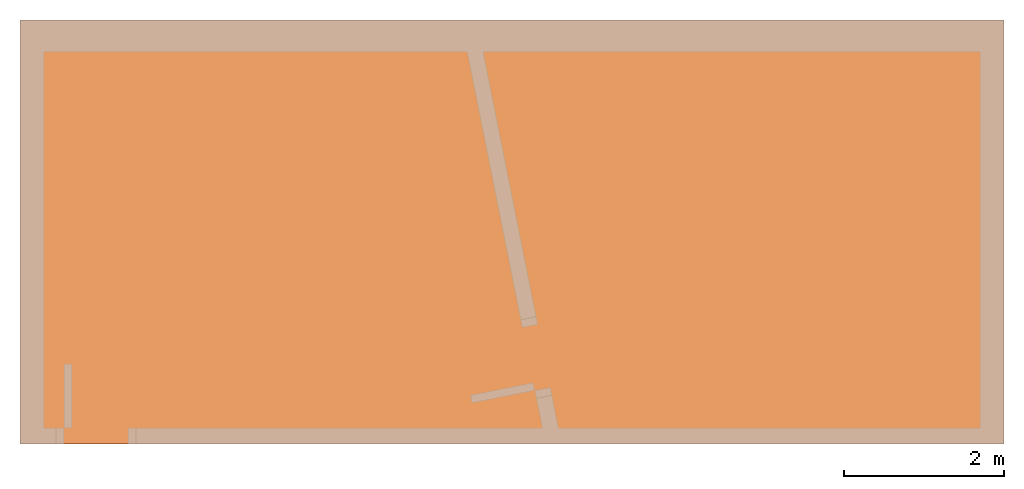
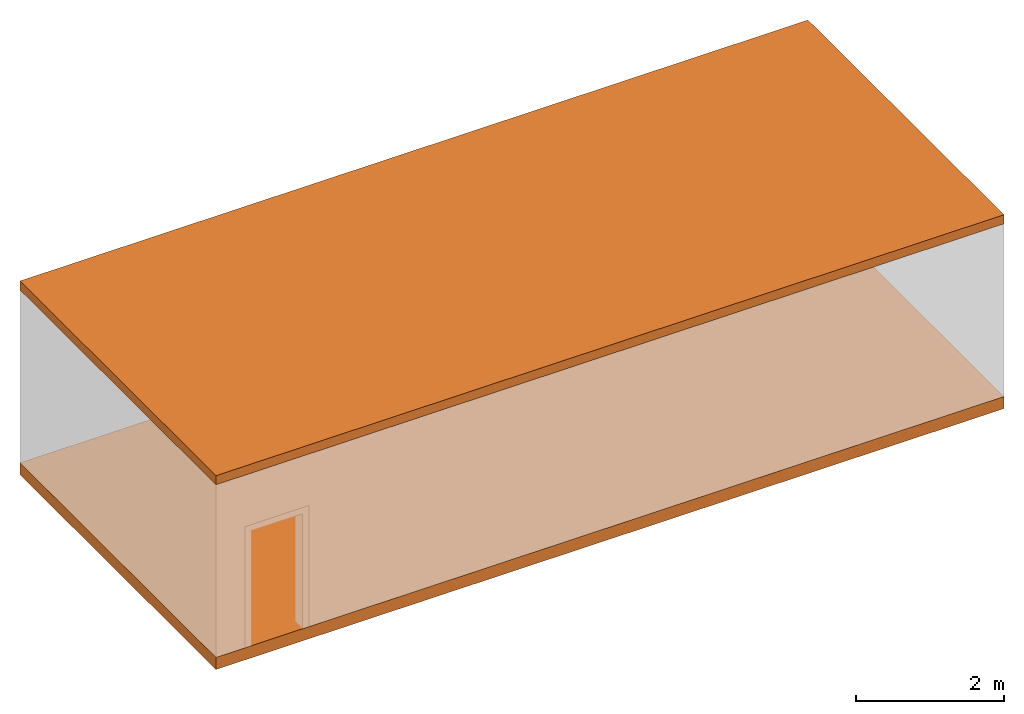
# One storey, part 3 of 3: 2 proxies, 1 element without a shape of its own.
"""IFC4 building model written with IfcOpenShell, lengths in metres."""

from ifc_helpers import new_model, entity, si_unit, converted_unit, direction, frame, origin_with_axes, place, context, subcontext, project, spatial, polyline, outline, extrude, element, aggregate, save


model = new_model("IFC4")

# Units and contexts
model_context = context("Model", 3, precision=1e-05, world=origin_with_axes(), true_north=direction((0.0, 1.0)))
body_context = subcontext(model_context, "Body", "Model", "MODEL_VIEW")
ifc_project = project(units=[si_unit("LENGTHUNIT", "METRE"), si_unit("AREAUNIT", "SQUARE_METRE"), si_unit("VOLUMEUNIT", "CUBIC_METRE"), converted_unit("PLANEANGLEUNIT", "DEGREE", entity("IfcPlaneAngleMeasure", 0.017453292519943295), si_unit("PLANEANGLEUNIT", "RADIAN"), dimensions=[0, 0, 0, 0, 0, 0, 0])], contexts=[model_context])

# Building, storey
building = spatial("IfcBuilding", under=ifc_project, Name="Default Building", CompositionType="ELEMENT")
storey = spatial("IfcBuildingStorey", under=building, Name="Floor", CompositionType="COMPLEX")

# Proxy
placement = place(None, origin_with_axes())
element("IfcBuildingElementProxy", 1, at=placement, inside=storey, Name="Slab", PredefinedType="COMPLEX", context=body_context, shape_type="SweptSolid", body=[
    extrude(outline(polyline([(-6.15, 2.65), (6.15, 2.65), (6.15, -2.65), (-6.15, -2.65), (-6.15, 2.65)])), frame((6.0, 2.55, 0.0), z_axis=(0.0, 0.0, 1.0), x_axis=(1.0, 0.0, 0.0)), (0.0, 0.0, -1.0), 0.2),
])

# Proxies
proxy_2 = element("IfcBuildingElementProxy", 2, inside=storey, PredefinedType="COMPLEX")
proxy_3 = element("IfcBuildingElementProxy", 3, at=placement, Name="Roof", PredefinedType="COMPLEX", context=body_context, shape_type="SweptSolid", body=[
    extrude(outline(polyline([(-6.15, 2.65), (6.15, 2.65), (6.15, -2.65), (-6.15, -2.65), (-6.15, 2.65)])), frame((6.0, 2.55, 3.0), z_axis=(0.0, 0.0, 1.0), x_axis=(1.0, 0.0, 0.0)), (0.0, 0.0, -1.0), 0.15),
])
aggregate(proxy_2, [proxy_3])

save(model, "model.ifc")
